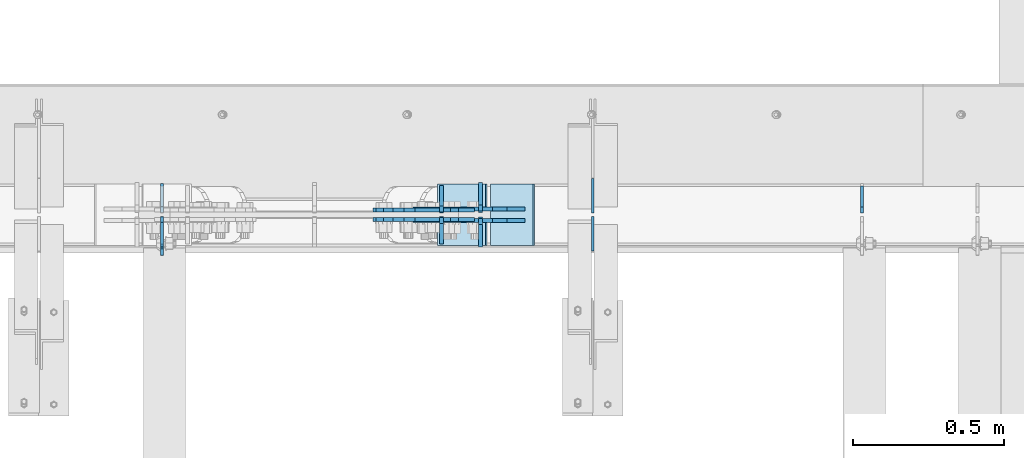
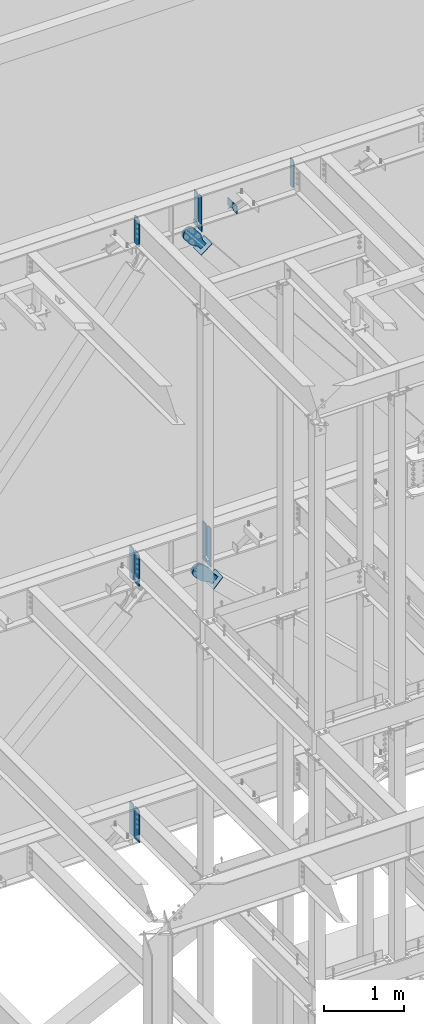
# One storey, part 1101 of 1179: 22 plates, 9 elements without a shape of their own.
"""IFC2X3 building model written with IfcOpenShell, lengths in millimetres."""

from ifc_helpers import new_model, si_unit, frame, origin_with_axes, place, context, subcontext, project, spatial, faceted_brep, material, type_object, element, aggregate, save


model = new_model("IFC2X3")

# Units and contexts
model_context = context("Model", 3, precision=1e-05, world=origin_with_axes())
body_context = subcontext(model_context, "Body", "Model", "MODEL_VIEW")
ifc_project = project(units=[si_unit("LENGTHUNIT", "METRE", prefix="MILLI"), si_unit("AREAUNIT", "SQUARE_METRE"), si_unit("VOLUMEUNIT", "CUBIC_METRE"), si_unit("MASSUNIT", "GRAM", prefix="KILO"), si_unit("TIMEUNIT", "SECOND"), si_unit("PLANEANGLEUNIT", "RADIAN"), si_unit("SOLIDANGLEUNIT", "STERADIAN"), si_unit("THERMODYNAMICTEMPERATUREUNIT", "DEGREE_CELSIUS"), si_unit("LUMINOUSINTENSITYUNIT", "LUMEN")], contexts=[model_context])

# Site, building, storey
site_placement = place(None, origin_with_axes())
site = spatial("IfcSite", under=ifc_project, at=site_placement, CompositionType="ELEMENT")
building_placement = place(site_placement, origin_with_axes())
building = spatial("IfcBuilding", under=site, at=building_placement, Name="Undefined", CompositionType="ELEMENT")
storey_placement = place(building_placement, origin_with_axes())
storey = spatial("IfcBuildingStorey", under=building, at=storey_placement, Name="Undefined", CompositionType="ELEMENT", Elevation=0.0)

# Assembly, plate
assembly_1_placement = place(storey_placement, origin_with_axes())
assembly_1 = element("IfcElementAssembly", 1, at=assembly_1_placement, inside=storey, Name="BEAM", AssemblyPlace="NOTDEFINED", PredefinedType="RIGID_FRAME")
ifc_material_1 = material(Name="STEEL/A36")
plate_type_1 = type_object("IfcPlateType", PredefinedType="NOTDEFINED")
plate_1_placement = place(assembly_1_placement, frame((11866.5620000839, 41193.24375, 12673.0125), z_axis=(0.0, 0.0, 1.0), x_axis=(0.0, -1.0, 0.0)))
plate_1 = element("IfcPlate", 2, at=plate_1_placement, type_object=plate_type_1, material=ifc_material_1, Name="PLATE", context=body_context, shape_type="Brep", body=[
    faceted_brep([(91.28125, -4.76250000000073, 425.450000000001), (91.28125, -4.76250000000073, 420.687499809264), (91.28125, 4.76250000000073, 420.687499809264), (91.28125, 4.76250000000073, 425.450000000001), (92.2479799225912, -4.76250000000073, 415.827420291219), (92.2479799225912, 4.76250000000073, 415.827420291219), (95.0009938230651, -4.76250000000073, 411.707243823065), (95.0009938230651, 4.76250000000073, 411.707243823065), (99.1211702912187, -4.76250000000073, 408.954229922587), (99.1211702912187, 4.76250000000073, 408.954229922587), (103.981249809265, -4.76250000000073, 407.987499999999), (103.981249809265, 4.76250000000073, 407.987499999999), (126.999999992826, -4.76249999999709, 407.9875), (127.0, 4.76249999999709, 407.9875), (0.0, -4.76249999999709, 406.400000762939), (19.0499992370605, -4.76249999999709, 425.45), (19.0499992370605, 4.76249999999709, 425.45), (0.0, 4.76249999999709, 406.400000762939), (0.0, -4.76250000000073, 19.0499992370605), (0.0, 4.76250000000073, 19.0499992370605), (19.0499992370605, -4.76250000000073, 0.0), (19.0499992370605, 4.76250000000073, 0.0), (127.0, -4.76250000000073, 0.0), (127.0, 4.76250000000073, 0.0)], [[[0, 1, 2, 3]], [[4, 5, 2, 1]], [[6, 7, 5, 4]], [[8, 9, 7, 6]], [[10, 11, 9, 8]], [[12, 13, 11, 10]], [[14, 15, 16, 17]], [[18, 14, 17, 19]], [[20, 18, 19, 21]], [[22, 20, 21, 23]], [[8, 6, 4, 1, 0, 15, 14, 18, 20, 22, 12, 10]], [[16, 15, 0, 3]], [[23, 21, 19, 17, 16, 3, 2, 5, 7, 9, 11, 13]], [[22, 23, 13, 12]]]),
])

assembly_2_placement = place(storey_placement, origin_with_axes())
assembly_2 = element("IfcElementAssembly", 3, at=assembly_2_placement, inside=storey, Name="BEAM", AssemblyPlace="NOTDEFINED", PredefinedType="RIGID_FRAME")
plate_2_placement = place(assembly_2_placement, frame((11866.5620000839, 41191.65625, 7489.825), z_axis=(0.0, 0.0, 1.0), x_axis=(0.0, -1.0, 0.0)))
plate_2 = element("IfcPlate", 4, at=plate_2_placement, type_object=plate_type_1, material=ifc_material_1, Name="PLATE", context=body_context, shape_type="Brep", body=[
    faceted_brep([(99.2187497618652, -4.76249999998072, 498.475), (99.21875, -4.76250000000073, 492.124999809264), (99.21875, 4.76250000000073, 492.124999809264), (99.2187499999927, 4.76250000001892, 498.475), (100.185479922588, -4.76250000000073, 487.264920291219), (100.185479922588, 4.76250000000073, 487.264920291219), (102.938493823065, -4.76250000000073, 483.144743823065), (102.938493823065, 4.76250000000073, 483.144743823065), (107.058670291219, -4.76250000000073, 480.391729922587), (107.058670291219, 4.76250000000073, 480.391729922587), (111.918749809265, -4.76250000000073, 479.424999999999), (111.918749809265, 4.76250000000073, 479.424999999999), (127.000007629395, -4.76250000000073, 479.424999999999), (127.000004683803, 4.76250000000073, 479.424999999999), (0.0, -4.76250000000073, 479.425006866455), (19.0499992370605, -4.76250000000073, 498.475006103516), (19.0499992370605, 4.76250000000073, 498.475006103516), (0.0, 4.76250000000073, 479.425006866455), (0.0, -4.76250000000073, 19.0499992370605), (0.0, 4.76250000000073, 19.0499992370605), (19.0499992370605, -4.76250000000073, 0.0), (19.0499992370605, 4.76250000000073, 0.0), (127.0, -4.76250000000073, 0.0), (127.0, 4.76250000000073, 0.0)], [[[0, 1, 2, 3]], [[4, 5, 2, 1]], [[6, 7, 5, 4]], [[8, 9, 7, 6]], [[10, 11, 9, 8]], [[12, 13, 11, 10]], [[14, 15, 16, 17]], [[18, 14, 17, 19]], [[20, 18, 19, 21]], [[22, 20, 21, 23]], [[8, 6, 4, 1, 0, 15, 14, 18, 20, 22, 12, 10]], [[16, 15, 0, 3]], [[23, 21, 19, 17, 16, 3, 2, 5, 7, 9, 11, 13]], [[22, 23, 13, 12]]]),
])

assembly_3_placement = place(storey_placement, origin_with_axes())
assembly_3 = element("IfcElementAssembly", 5, at=assembly_3_placement, inside=storey, Name="BEAM", AssemblyPlace="NOTDEFINED", PredefinedType="RIGID_FRAME")
plate_3_placement = place(assembly_3_placement, frame((11866.5619473748, 41191.6562498809, 3578.225), z_axis=(0.0, 0.0, 1.0), x_axis=(0.0, -1.0, 0.0)))
plate_3 = element("IfcPlate", 6, at=plate_3_placement, type_object=plate_type_1, material=ifc_material_1, Name="PLATE", context=body_context, shape_type="Brep", body=[
    faceted_brep([(100.185729626639, -4.76249977056068, 493.614920291231), (100.185729712364, 4.76250000001892, 493.614920291231), (99.2189997897731, 4.76250000002074, 498.475), (99.218999704055, -4.76249999998072, 498.475), (102.93874352712, -4.76249979533713, 489.494743823075), (102.938743612845, 4.76250000002074, 489.494743823075), (107.058919995281, -4.76249983241905, 486.741729922598), (107.058920081006, 4.76250000002074, 486.741729922598), (111.918999513335, -4.76249987616211, 485.775000000015), (111.918999599053, 4.76250000002074, 485.775000000015), (127.000004753965, -4.76249999997526, 485.775), (127.000004873044, 4.76250000002437, 485.775), (0.0, -4.76250000000073, 479.425006866455), (19.0499992370605, -4.76250000000073, 498.475006103516), (19.0499992370605, 4.76250000000073, 498.475006103516), (0.0, 4.76250000000073, 479.425006866455), (0.0, -4.76250000000073, 19.0499992370605), (0.0, 4.76250000000073, 19.0499992370605), (19.0499992370605, -4.76250000000073, 0.0), (19.0499992370605, 4.76250000000073, 0.0), (127.0, -4.76250000000073, 0.0), (127.0, 4.76250000000073, 0.0)], [[[0, 1, 2, 3]], [[4, 5, 1, 0]], [[6, 7, 5, 4]], [[8, 9, 7, 6]], [[10, 11, 9, 8]], [[12, 13, 14, 15]], [[16, 12, 15, 17]], [[18, 16, 17, 19]], [[20, 18, 19, 21]], [[6, 4, 0, 3, 13, 12, 16, 18, 20, 10, 8]], [[14, 13, 3, 2]], [[21, 19, 17, 15, 14, 2, 1, 5, 7, 9, 11]], [[20, 21, 11, 10]]]),
])

# Plate
plate_type_2 = type_object("IfcPlateType", PredefinedType="NOTDEFINED")
plate_4_placement = place(assembly_1_placement, frame((14177.9620000839, 41204.35625, 12673.0125), z_axis=(0.0, 0.0, 1.0), x_axis=(0.0, 1.0, 0.0)))
plate_4 = element("IfcPlate", 7, at=plate_4_placement, type_object=plate_type_2, material=ifc_material_1, Name="PLATE", context=body_context, shape_type="Brep", body=[
    faceted_brep([(0.0, -4.76250000000073, 19.0499992370605), (0.0, -4.76249999999709, 406.400000762939), (0.0, 4.76249999999709, 406.400000762939), (0.0, 4.76250000000073, 19.0499992370605), (19.0499992370605, -4.76249999999709, 425.45), (19.0499992370605, 4.76249999999709, 425.45), (88.9000015258789, -4.76250000000073, 425.450012207031), (88.9000015258789, 4.76250000000073, 425.450012207031), (88.8999999999996, -4.76250000000005, 0.0), (88.8999999999996, 4.76250000000005, 0.0), (19.0499992370605, -4.76250000000073, 0.0), (19.0499992370605, 4.76250000000073, 0.0)], [[[0, 1, 2, 3]], [[1, 4, 5, 2]], [[4, 6, 7, 5]], [[6, 8, 9, 7]], [[8, 10, 11, 9]], [[10, 0, 3, 11]], [[5, 7, 9, 11, 3, 2]], [[10, 8, 6, 4, 1, 0]]]),
])

ifc_material_2 = material(Name="STEEL/A572-GR.50")
plate_type_3 = type_object("IfcPlateType", PredefinedType="NOTDEFINED")
plate_5_placement = place(assembly_2_placement, frame((12918.0828125064, 41205.94375, 7489.825), z_axis=(0.0, 1.0, 0.0), x_axis=(0.0, 0.0, 1.0)))
plate_5 = element("IfcPlate", 8, at=plate_5_placement, type_object=plate_type_3, material=ifc_material_2, Name="PLATE", context=body_context, shape_type="Brep", body=[
    faceted_brep([(0.0, -6.34999999998763, 17.4624996185248), (0.0, -6.35000000000036, 99.21875), (0.0, 6.35000000000036, 99.21875), (0.0, 6.35000000000582, 17.4624996185175), (498.475, -6.35000000000036, 99.21875), (498.475, 6.35000000000036, 99.21875), (498.474999999775, -6.34999999979482, 17.4624996185303), (498.474999999769, 6.35000000019681, 17.4624996185303), (481.012500381255, -6.34999999980209, 0.0), (481.01250038125, 6.35000000019136, 0.0), (17.4624996185303, -6.34999999999309, 1.81898940354586e-12), (17.4624996185303, 6.34999999999854, -1.81898940354586e-12)], [[[0, 1, 2, 3]], [[1, 4, 5, 2]], [[4, 6, 7, 5]], [[6, 8, 9, 7]], [[8, 10, 11, 9]], [[10, 0, 3, 11]], [[5, 7, 9, 11, 3, 2]], [[10, 8, 6, 4, 1, 0]]]),
])

plate_6_placement = place(assembly_2_placement, frame((12918.0828125064, 41191.65625, 7489.825), z_axis=(0.0, -1.0, 0.0), x_axis=(0.0, 0.0, 1.0)))
plate_6 = element("IfcPlate", 9, at=plate_6_placement, type_object=plate_type_3, material=ifc_material_2, Name="PLATE", context=body_context, shape_type="Brep", body=[
    faceted_brep([(0.0, -6.34999999998763, 17.4624996185248), (0.0, -6.35000000000036, 99.21875), (0.0, 6.35000000000036, 99.21875), (0.0, 6.35000000000582, 17.4624996185175), (498.475, -6.35000000000036, 99.21875), (498.475, 6.35000000000036, 99.21875), (498.474999999775, -6.34999999979482, 17.4624996185303), (498.474999999769, 6.35000000019681, 17.4624996185303), (481.012500381255, -6.34999999980209, 0.0), (481.01250038125, 6.35000000019136, 0.0), (17.4624996185303, -6.34999999999309, 1.81898940354586e-12), (17.4624996185303, 6.34999999999854, -1.81898940354586e-12)], [[[0, 1, 2, 3]], [[1, 4, 5, 2]], [[4, 6, 7, 5]], [[6, 8, 9, 7]], [[8, 10, 11, 9]], [[10, 0, 3, 11]], [[5, 7, 9, 11, 3, 2]], [[10, 8, 6, 4, 1, 0]]]),
])

plate_type_4 = type_object("IfcPlateType", PredefinedType="NOTDEFINED")
plate_7_placement = place(assembly_2_placement, frame((11866.5620000839, 41205.94375, 7489.825), z_axis=(0.0, 0.0, 1.0), x_axis=(0.0, 1.0, 0.0)))
plate_7 = element("IfcPlate", 10, at=plate_7_placement, type_object=plate_type_4, material=ifc_material_1, Name="PLATE", context=body_context, shape_type="Brep", body=[
    faceted_brep([(0.0, -4.76250000000073, 19.0499992370605), (0.0, -4.76250000000073, 479.425006866455), (0.0, 4.76250000000073, 479.425006866455), (0.0, 4.76250000000073, 19.0499992370605), (19.0499992370605, -4.76250000000073, 498.475006103516), (19.0499992370605, 4.76250000000073, 498.475006103516), (95.25, -4.76250000000073, 498.475006103516), (95.25, 4.76250000000073, 498.475006103516), (95.25, -4.76250000000073, 0.0), (95.25, 4.76250000000073, 0.0), (19.0499992370605, -4.76250000000073, 0.0), (19.0499992370605, 4.76250000000073, 0.0)], [[[0, 1, 2, 3]], [[1, 4, 5, 2]], [[4, 6, 7, 5]], [[6, 8, 9, 7]], [[8, 10, 11, 9]], [[10, 0, 3, 11]], [[5, 7, 9, 11, 3, 2]], [[10, 8, 6, 4, 1, 0]]]),
])

plate_8_placement = place(assembly_3_placement, frame((11866.5619473541, 41205.94375, 3578.225), z_axis=(0.0, 0.0, 1.0), x_axis=(0.0, 1.0, 0.0)))
plate_8 = element("IfcPlate", 11, at=plate_8_placement, type_object=plate_type_4, material=ifc_material_1, Name="PLATE", context=body_context, shape_type="Brep", body=[
    faceted_brep([(0.0, -4.76250000000073, 19.0499992370605), (0.0, -4.76250000000073, 479.425006866455), (0.0, 4.76250000000073, 479.425006866455), (0.0, 4.76250000000073, 19.0499992370605), (19.0499992370605, -4.76250000000073, 498.475006103516), (19.0499992370605, 4.76250000000073, 498.475006103516), (95.25, -4.76250000000073, 498.475006103516), (95.25, 4.76250000000073, 498.475006103516), (95.25, -4.76250000000073, 0.0), (95.25, 4.76250000000073, 0.0), (19.0499992370605, -4.76250000000073, 0.0), (19.0499992370605, 4.76250000000073, 0.0)], [[[0, 1, 2, 3]], [[1, 4, 5, 2]], [[4, 6, 7, 5]], [[6, 8, 9, 7]], [[8, 10, 11, 9]], [[10, 0, 3, 11]], [[5, 7, 9, 11, 3, 2]], [[10, 8, 6, 4, 1, 0]]]),
])

aggregate(assembly_3, [plate_8, plate_3])

# Assembly, plate
assembly_4_placement = place(storey_placement, origin_with_axes())
assembly_4 = element("IfcElementAssembly", 12, at=assembly_4_placement, inside=storey, Name="Plate", AssemblyPlace="NOTDEFINED", PredefinedType="RIGID_FRAME")
plate_type_5 = type_object("IfcPlateType", PredefinedType="NOTDEFINED")
plate_9_placement = place(assembly_4_placement, frame((12778.2065319838, 41300.4, 12208.4235723899), z_axis=(0.782937860640373, 0.0, 0.622099916714249), x_axis=(0.0, -1.0, 0.0)))
plate_9 = element("IfcPlate", 13, at=plate_9_placement, type_object=plate_type_5, material=ifc_material_1, Name="Plate", context=body_context, shape_type="Brep", body=[
    faceted_brep([(0.0, -3.17500000000109, 0.0), (0.0, -3.17500000000291, 203.200000000368), (0.0, 3.17499999998836, 203.200000000361), (0.0, 3.17500000000109, 7.27595761418343e-12), (203.199999999997, -3.17500000000291, 203.200000000368), (203.199999999997, 3.17499999998836, 203.200000000361), (203.199999999997, -3.17499999999927, 3.63797880709171e-12), (203.199999999997, 3.17499999999382, -3.63797880709171e-12)], [[[0, 1, 2, 3]], [[1, 4, 5, 2]], [[4, 6, 7, 5]], [[6, 0, 3, 7]], [[5, 7, 3, 2]], [[6, 4, 1, 0]]]),
])
aggregate(assembly_4, [plate_9])

assembly_5_placement = place(storey_placement, origin_with_axes())
assembly_5 = element("IfcElementAssembly", 14, at=assembly_5_placement, inside=storey, Name="Plate", AssemblyPlace="NOTDEFINED", PredefinedType="RIGID_FRAME")
plate_10_placement = place(assembly_5_placement, frame((12953.4754471268, 41300.4, 7040.16901450949), z_axis=(0.691222646058185, 0.0, 0.722641857060828), x_axis=(0.0, -1.0, 0.0)))
plate_10 = element("IfcPlate", 15, at=plate_10_placement, type_object=plate_type_5, material=ifc_material_1, Name="Plate", context=body_context, shape_type="Brep", body=[
    faceted_brep([(0.0, -3.17500000000109, 0.0), (0.0, -3.17500000000291, 203.200000000368), (0.0, 3.17499999998836, 203.200000000361), (0.0, 3.17500000000109, 7.27595761418343e-12), (203.199999999997, -3.17500000000291, 203.200000000368), (203.199999999997, 3.17499999998836, 203.200000000361), (203.199999999997, -3.17499999999927, 3.63797880709171e-12), (203.199999999997, 3.17499999999382, -3.63797880709171e-12)], [[[0, 1, 2, 3]], [[1, 4, 5, 2]], [[4, 6, 7, 5]], [[6, 0, 3, 7]], [[5, 7, 3, 2]], [[6, 4, 1, 0]]]),
])
aggregate(assembly_5, [plate_10])

# Plate
plate_type_6 = type_object("IfcPlateType", PredefinedType="NOTDEFINED")
plate_11_placement = place(assembly_1_placement, frame((12788.9, 41208.325, 12652.375), z_axis=(0.0, 1.0, 0.0), x_axis=(0.0, 0.0, -1.0)))
plate_11 = element("IfcPlate", 16, at=plate_11_placement, type_object=plate_type_6, material=ifc_material_2, Name="PLATE", context=body_context, shape_type="Brep", body=[
    faceted_brep([(0.0, 6.35000000000036, 19.0499999999993), (19.0500000000002, 6.35000000000036, 0.0), (19.0500000000002, -6.35000000000036, 0.0), (0.0, -6.35000000000036, 19.0499999999993), (0.0, -6.35000000000036, 87.3125), (0.0, 6.35000000000036, 87.3125), (88.7851254133348, -6.35000000000036, 87.3125), (88.7851254133348, 6.35000000000036, 87.3125), (88.7851254133348, -6.35000000000036, 0.0), (88.7851254133348, 6.35000000000036, 0.0)], [[[0, 1, 2, 3]], [[4, 5, 0, 3]], [[4, 6, 7, 5]], [[6, 8, 9, 7]], [[9, 8, 2, 1]], [[5, 7, 9, 1, 0]], [[8, 6, 4, 3, 2]]]),
])

plate_12_placement = place(assembly_1_placement, frame((12788.9, 41189.275, 12652.375), z_axis=(0.0, -1.0, 0.0), x_axis=(0.0, 0.0, -1.0)))
plate_12 = element("IfcPlate", 17, at=plate_12_placement, type_object=plate_type_6, material=ifc_material_2, Name="PLATE", context=body_context, shape_type="Brep", body=[
    faceted_brep([(0.0, 6.35000000000036, 19.0499999999993), (19.0500000000002, 6.35000000000036, 0.0), (19.0500000000002, -6.35000000000036, 0.0), (0.0, -6.35000000000036, 19.0499999999993), (0.0, -6.35000000000036, 87.3125), (0.0, 6.35000000000036, 87.3125), (88.7851254133348, -6.35000000000036, 87.3125), (88.7851254133348, 6.35000000000036, 87.3125), (88.7851254133348, -6.35000000000036, 0.0), (88.7851254133348, 6.35000000000036, 0.0)], [[[0, 1, 2, 3]], [[4, 5, 0, 3]], [[4, 6, 7, 5]], [[6, 8, 9, 7]], [[9, 8, 2, 1]], [[5, 7, 9, 1, 0]], [[8, 6, 4, 3, 2]]]),
])

plate_type_7 = type_object("IfcPlateType", PredefinedType="NOTDEFINED")
plate_13_placement = place(assembly_1_placement, frame((12788.9, 41104.34375, 12673.0125), z_axis=(0.0, 0.0, 1.0), x_axis=(0.0, 1.0, 0.0)))
plate_13 = element("IfcPlate", 18, at=plate_13_placement, type_object=plate_type_7, material=ifc_material_2, Name="PLATE", context=body_context, shape_type="Brep", body=[
    faceted_brep([(0.0, -6.34999999999854, 0.0), (0.0, -6.34999999999991, 425.450012207031), (0.0, 6.34999999999991, 425.450012207031), (0.0, 6.34999999999854, 0.0), (69.8500022888184, -6.34999999999991, 425.450012207031), (69.8500022888184, 6.34999999999991, 425.450012207031), (88.9000015258789, -6.34999999999991, 406.400012969971), (88.9000015258789, 6.34999999999991, 406.400012969971), (88.9000015258789, -6.34999999999991, 19.0499992370605), (88.9000015258789, 6.34999999999991, 19.0499992370605), (69.849999425729, -6.34999999999854, 0.0), (69.849999425729, 6.34999999999854, 0.0)], [[[0, 1, 2, 3]], [[1, 4, 5, 2]], [[4, 6, 7, 5]], [[6, 8, 9, 7]], [[8, 10, 11, 9]], [[10, 0, 3, 11]], [[5, 7, 9, 11, 3, 2]], [[10, 8, 6, 4, 1, 0]]]),
])

plate_14_placement = place(assembly_1_placement, frame((12788.9, 41204.35625, 12673.0125), z_axis=(0.0, 0.0, 1.0), x_axis=(0.0, 1.0, 0.0)))
plate_14 = element("IfcPlate", 19, at=plate_14_placement, type_object=plate_type_7, material=ifc_material_2, Name="PLATE", context=body_context, shape_type="Brep", body=[
    faceted_brep([(0.0, -6.35000000000036, 19.0499999999993), (0.0, -6.34999999999991, 406.400012969971), (0.0, 6.34999999999991, 406.400012969971), (0.0, 6.35000000000036, 19.0499999999993), (19.0499992370605, -6.34999999999991, 425.450012207031), (19.0499992370605, 6.34999999999991, 425.450012207031), (88.9000015258789, -6.34999999999991, 425.450012207031), (88.9000015258789, 6.34999999999991, 425.450012207031), (88.9000015258789, -6.34999999999991, 0.0), (88.9000015258789, 6.34999999999991, 0.0), (19.0500000000002, -6.35000000000036, 0.0), (19.0500000000002, 6.35000000000036, 0.0)], [[[0, 1, 2, 3]], [[1, 4, 5, 2]], [[4, 6, 7, 5]], [[6, 8, 9, 7]], [[8, 10, 11, 9]], [[3, 11, 10, 0]], [[5, 7, 9, 11, 3, 2]], [[10, 8, 6, 4, 1, 0]]]),
])

plate_type_8 = type_object("IfcPlateType", PredefinedType="NOTDEFINED")
plate_15_placement = place(assembly_2_placement, frame((12918.0828125064, 41211.5, 7464.42500040788), z_axis=(0.0, 1.0, 0.0), x_axis=(0.0, 0.0, -1.0)))
plate_15 = element("IfcPlate", 20, at=plate_15_placement, type_object=plate_type_8, material=ifc_material_2, Name="PLATE", context=body_context, shape_type="Brep", body=[
    faceted_brep([(0.0, 6.35000000000036, 19.0499999999993), (19.0500000000002, 6.35000000000036, 0.0), (19.0500000000002, -6.35000000000036, 0.0), (0.0, -6.35000000000036, 19.0499999999993), (0.0, -6.35000000000036, 93.6625000000058), (0.0, 6.35000000000036, 93.6625000000058), (63.5020087381745, -6.35000000000036, 93.6625000000058), (63.5020087381745, 6.35000000000036, 93.6625000000058), (63.5020087381745, -6.35000000000036, 0.0), (63.5020087381745, 6.35000000000036, 0.0)], [[[0, 1, 2, 3]], [[4, 5, 0, 3]], [[4, 6, 7, 5]], [[6, 8, 9, 7]], [[9, 8, 2, 1]], [[5, 7, 9, 1, 0]], [[8, 6, 4, 3, 2]]]),
])

plate_16_placement = place(assembly_2_placement, frame((12918.0828125064, 41186.1, 7464.42500040788), z_axis=(0.0, -1.0, 0.0), x_axis=(0.0, 0.0, -1.0)))
plate_16 = element("IfcPlate", 21, at=plate_16_placement, type_object=plate_type_8, material=ifc_material_2, Name="PLATE", context=body_context, shape_type="Brep", body=[
    faceted_brep([(0.0, 6.35000000000036, 19.0499999999993), (19.0500000000002, 6.35000000000036, 0.0), (19.0500000000002, -6.35000000000036, 0.0), (0.0, -6.35000000000036, 19.0499999999993), (0.0, -6.35000000000036, 93.6625000000058), (0.0, 6.35000000000036, 93.6625000000058), (63.5020087381745, -6.35000000000036, 93.6625000000058), (63.5020087381745, 6.35000000000036, 93.6625000000058), (63.5020087381745, -6.35000000000036, 0.0), (63.5020087381745, 6.35000000000036, 0.0)], [[[0, 1, 2, 3]], [[4, 5, 0, 3]], [[4, 6, 7, 5]], [[6, 8, 9, 7]], [[9, 8, 2, 1]], [[5, 7, 9, 1, 0]], [[8, 6, 4, 3, 2]]]),
])

aggregate(assembly_2, [plate_15, plate_16, plate_5, plate_6, plate_7, plate_2])

# Assembly, plate
assembly_6_placement = place(storey_placement, origin_with_axes())
assembly_6 = element("IfcElementAssembly", 22, at=assembly_6_placement, inside=storey, AssemblyPlace="NOTDEFINED", PredefinedType="RIGID_FRAME")
plate_type_9 = type_object("IfcPlateType", PredefinedType="NOTDEFINED")
plate_17_placement = place(assembly_6_placement, frame((12846.4064600926, 41214.675, 12363.9942449933), z_axis=(-0.782937860640373, 0.0, -0.622099916714249), x_axis=(0.622099916714252, 0.0, -0.782937860640371)))
plate_17 = element("IfcPlate", 23, at=plate_17_placement, type_object=plate_type_9, material=ifc_material_1, context=body_context, shape_type="Brep", body=[
    faceted_brep([(0.0, -6.34999999999854, 0.0), (-101.600000000007, -6.34999999999854, -45.085691726028), (-101.600000000007, 6.34999999999854, -45.085691726028), (0.0, 6.34999999999854, 0.0), (-245.369242322517, -6.34999999999854, -45.085691725908), (-245.369242322517, 6.34999999999854, -45.085691725908), (-281.212328722571, -6.34999999999854, -37.9560585558283), (-281.212328722571, 6.34999999999854, -37.9560585558283), (-311.598630136563, -6.34999999999854, -17.6525810655148), (-311.598630136563, 6.34999999999854, -17.6525810655148), (-331.902107626699, -6.34999999999854, 12.7337203485949), (-331.902107626699, 6.34999999999854, 12.7337203485949), (-339.031740796561, -6.34999999999854, 48.5768098006738), (-339.031740796561, 6.34999999999854, 48.5768098006738), (-331.902107626408, -6.34999999999854, 84.4198962005139), (-331.902107626408, 6.34999999999854, 84.4198962005139), (-311.598630136172, -6.34999999999854, 114.806197614322), (-311.598630136172, 6.34999999999854, 114.806197614322), (-281.212328722244, -6.34999999999854, 135.109675104381), (-281.212328722244, 6.34999999999854, 135.109675104381), (-245.369240796288, -6.34999999999854, 142.239308274318), (-245.369240796288, 6.34999999999854, 142.239308274318), (-101.599999999052, -6.34999999999854, 142.239308274202), (-101.599999999052, 6.34999999999854, 142.239308274202), (4.938556230627e-10, -6.34999999999854, 97.1536165479993), (4.938556230627e-10, 6.34999999999854, 97.1536165479993), (82.5500000003167, -6.34999999999854, 97.1536165479301), (82.5500000003167, 6.34999999999854, 97.1536165479301), (82.550000000203, -6.34999999999854, 1.2732925824821e-10), (82.550000000203, 6.34999999999854, 1.2732925824821e-10)], [[[0, 1, 2, 3]], [[1, 4, 5, 2]], [[4, 6, 7, 5]], [[6, 8, 9, 7]], [[8, 10, 11, 9]], [[10, 12, 13, 11]], [[12, 14, 15, 13]], [[14, 16, 17, 15]], [[16, 18, 19, 17]], [[18, 20, 21, 19]], [[20, 22, 23, 21]], [[22, 24, 25, 23]], [[24, 26, 27, 25]], [[26, 28, 29, 27]], [[28, 0, 3, 29]], [[5, 7, 9, 11, 13, 15, 17, 19, 21, 23, 25, 27, 29, 3, 2]], [[28, 26, 24, 22, 20, 18, 16, 14, 12, 10, 8, 6, 4, 1, 0]]]),
])
aggregate(assembly_6, [plate_17])

assembly_7_placement = place(storey_placement, origin_with_axes())
assembly_7 = element("IfcElementAssembly", 24, at=assembly_7_placement, inside=storey, AssemblyPlace="NOTDEFINED", PredefinedType="RIGID_FRAME")
plate_18_placement = place(assembly_7_placement, frame((12846.4064600926, 41182.925, 12363.9942449933), z_axis=(-0.782937860640373, 0.0, -0.622099916714249), x_axis=(0.622099916714252, 0.0, -0.782937860640371)))
plate_18 = element("IfcPlate", 25, at=plate_18_placement, type_object=plate_type_9, material=ifc_material_1, context=body_context, shape_type="Brep", body=[
    faceted_brep([(0.0, -6.34999999999854, 0.0), (-101.600000000007, -6.34999999999854, -45.085691726028), (-101.600000000007, 6.34999999999854, -45.085691726028), (0.0, 6.34999999999854, 0.0), (-245.369242322517, -6.34999999999854, -45.085691725908), (-245.369242322517, 6.34999999999854, -45.085691725908), (-281.212328722571, -6.34999999999854, -37.9560585558283), (-281.212328722571, 6.34999999999854, -37.9560585558283), (-311.598630136563, -6.34999999999854, -17.6525810655148), (-311.598630136563, 6.34999999999854, -17.6525810655148), (-331.902107626699, -6.34999999999854, 12.7337203485949), (-331.902107626699, 6.34999999999854, 12.7337203485949), (-339.031740796561, -6.34999999999854, 48.5768098006738), (-339.031740796561, 6.34999999999854, 48.5768098006738), (-331.902107626408, -6.34999999999854, 84.4198962005139), (-331.902107626408, 6.34999999999854, 84.4198962005139), (-311.598630136172, -6.34999999999854, 114.806197614322), (-311.598630136172, 6.34999999999854, 114.806197614322), (-281.212328722244, -6.34999999999854, 135.109675104381), (-281.212328722244, 6.34999999999854, 135.109675104381), (-245.369240796288, -6.34999999999854, 142.239308274318), (-245.369240796288, 6.34999999999854, 142.239308274318), (-101.599999999052, -6.34999999999854, 142.239308274202), (-101.599999999052, 6.34999999999854, 142.239308274202), (4.938556230627e-10, -6.34999999999854, 97.1536165479993), (4.938556230627e-10, 6.34999999999854, 97.1536165479993), (82.5500000003167, -6.34999999999854, 97.1536165479301), (82.5500000003167, 6.34999999999854, 97.1536165479301), (82.550000000203, -6.34999999999854, 1.2732925824821e-10), (82.550000000203, 6.34999999999854, 1.2732925824821e-10)], [[[0, 1, 2, 3]], [[1, 4, 5, 2]], [[4, 6, 7, 5]], [[6, 8, 9, 7]], [[8, 10, 11, 9]], [[10, 12, 13, 11]], [[12, 14, 15, 13]], [[14, 16, 17, 15]], [[16, 18, 19, 17]], [[18, 20, 21, 19]], [[20, 22, 23, 21]], [[22, 24, 25, 23]], [[24, 26, 27, 25]], [[26, 28, 29, 27]], [[28, 0, 3, 29]], [[5, 7, 9, 11, 13, 15, 17, 19, 21, 23, 25, 27, 29, 3, 2]], [[28, 26, 24, 22, 20, 18, 16, 14, 12, 10, 8, 6, 4, 1, 0]]]),
])
aggregate(assembly_7, [plate_18])

assembly_8_placement = place(storey_placement, origin_with_axes())
assembly_8 = element("IfcElementAssembly", 26, at=assembly_8_placement, inside=storey, AssemblyPlace="NOTDEFINED", PredefinedType="RIGID_FRAME")
plate_19_placement = place(assembly_8_placement, frame((13005.1163529212, 41217.85, 7208.98998808252), z_axis=(-0.691222646058184, 0.0, -0.722641857060828), x_axis=(0.722641857060828, 0.0, -0.691222646058184)))
plate_19 = element("IfcPlate", 27, at=plate_19_placement, type_object=plate_type_9, material=ifc_material_1, context=body_context, shape_type="Brep", body=[
    faceted_brep([(0.0, -6.34999999999854, 0.0), (-101.599999999963, -6.34999999999854, -37.5700345970108), (-101.599999999963, 6.34999999999854, -37.5700345970108), (0.0, 6.34999999999854, 0.0), (-245.369242323884, -6.34999999999854, -37.5700345970945), (-245.369242323884, 6.34999999999854, -37.5700345970945), (-281.212328723803, -6.34999999999854, -30.4404014271258), (-281.212328723803, 6.34999999999854, -30.4404014271258), (-311.598630137756, -6.34999999999854, -10.1369239370142), (-311.598630137756, 6.34999999999854, -10.1369239370142), (-331.902107627997, -6.34999999999854, 20.24937747687), (-331.902107627997, 6.34999999999854, 20.24937747687), (-339.031740798124, -6.34999999999854, 56.0924669287269), (-339.031740798124, 6.34999999999854, 56.0924669287269), (-331.902107628228, -6.34999999999854, 91.9355533287926), (-331.902107628228, 6.34999999999854, 91.9355533287926), (-311.598630138099, -6.34999999999854, 122.321854742866), (-311.598630138099, 6.34999999999854, 122.321854742866), (-281.212328724136, -6.34999999999854, 142.625332233139), (-281.212328724136, 6.34999999999854, 142.625332233139), (-245.36924079839, -6.34999999999854, 149.754965403199), (-245.36924079839, 6.34999999999854, 149.754965403199), (-101.600000000685, -6.34999999999854, 149.75496540329), (-101.600000000685, 6.34999999999854, 149.75496540329), (-4.35647962149233e-10, -6.34999999999854, 112.184930806416), (-4.35647962149233e-10, 6.34999999999854, 112.184930806416), (82.5499999996491, -6.34999999999854, 112.184930806461), (82.5499999996491, 6.34999999999854, 112.184930806461), (82.550000000203, -6.34999999999854, 1.2732925824821e-10), (82.550000000203, 6.34999999999854, 1.2732925824821e-10)], [[[0, 1, 2, 3]], [[1, 4, 5, 2]], [[4, 6, 7, 5]], [[6, 8, 9, 7]], [[8, 10, 11, 9]], [[10, 12, 13, 11]], [[12, 14, 15, 13]], [[14, 16, 17, 15]], [[16, 18, 19, 17]], [[18, 20, 21, 19]], [[20, 22, 23, 21]], [[22, 24, 25, 23]], [[24, 26, 27, 25]], [[26, 28, 29, 27]], [[28, 0, 3, 29]], [[5, 7, 9, 11, 13, 15, 17, 19, 21, 23, 25, 27, 29, 3, 2]], [[28, 26, 24, 22, 20, 18, 16, 14, 12, 10, 8, 6, 4, 1, 0]]]),
])
aggregate(assembly_8, [plate_19])

assembly_9_placement = place(storey_placement, origin_with_axes())
assembly_9 = element("IfcElementAssembly", 28, at=assembly_9_placement, inside=storey, AssemblyPlace="NOTDEFINED", PredefinedType="RIGID_FRAME")
plate_20_placement = place(assembly_9_placement, frame((13005.1163529212, 41179.75, 7208.98998808252), z_axis=(-0.691222646058184, 0.0, -0.722641857060828), x_axis=(0.722641857060828, 0.0, -0.691222646058184)))
plate_20 = element("IfcPlate", 29, at=plate_20_placement, type_object=plate_type_9, material=ifc_material_1, context=body_context, shape_type="Brep", body=[
    faceted_brep([(0.0, -6.34999999999854, 0.0), (-101.599999999963, -6.34999999999854, -37.5700345970108), (-101.599999999963, 6.34999999999854, -37.5700345970108), (0.0, 6.34999999999854, 0.0), (-245.369242323884, -6.34999999999854, -37.5700345970945), (-245.369242323884, 6.34999999999854, -37.5700345970945), (-281.212328723803, -6.34999999999854, -30.4404014271258), (-281.212328723803, 6.34999999999854, -30.4404014271258), (-311.598630137756, -6.34999999999854, -10.1369239370142), (-311.598630137756, 6.34999999999854, -10.1369239370142), (-331.902107627997, -6.34999999999854, 20.24937747687), (-331.902107627997, 6.34999999999854, 20.24937747687), (-339.031740798124, -6.34999999999854, 56.0924669287269), (-339.031740798124, 6.34999999999854, 56.0924669287269), (-331.902107628228, -6.34999999999854, 91.9355533287926), (-331.902107628228, 6.34999999999854, 91.9355533287926), (-311.598630138099, -6.34999999999854, 122.321854742866), (-311.598630138099, 6.34999999999854, 122.321854742866), (-281.212328724136, -6.34999999999854, 142.625332233139), (-281.212328724136, 6.34999999999854, 142.625332233139), (-245.36924079839, -6.34999999999854, 149.754965403199), (-245.36924079839, 6.34999999999854, 149.754965403199), (-101.600000000685, -6.34999999999854, 149.75496540329), (-101.600000000685, 6.34999999999854, 149.75496540329), (-4.35647962149233e-10, -6.34999999999854, 112.184930806416), (-4.35647962149233e-10, 6.34999999999854, 112.184930806416), (82.5499999996491, -6.34999999999854, 112.184930806461), (82.5499999996491, 6.34999999999854, 112.184930806461), (82.550000000203, -6.34999999999854, 1.2732925824821e-10), (82.550000000203, 6.34999999999854, 1.2732925824821e-10)], [[[0, 1, 2, 3]], [[1, 4, 5, 2]], [[4, 6, 7, 5]], [[6, 8, 9, 7]], [[8, 10, 11, 9]], [[10, 12, 13, 11]], [[12, 14, 15, 13]], [[14, 16, 17, 15]], [[16, 18, 19, 17]], [[18, 20, 21, 19]], [[20, 22, 23, 21]], [[22, 24, 25, 23]], [[24, 26, 27, 25]], [[26, 28, 29, 27]], [[28, 0, 3, 29]], [[5, 7, 9, 11, 13, 15, 17, 19, 21, 23, 25, 27, 29, 3, 2]], [[28, 26, 24, 22, 20, 18, 16, 14, 12, 10, 8, 6, 4, 1, 0]]]),
])
aggregate(assembly_9, [plate_20])

# Plate
plate_type_10 = type_object("IfcPlateType", PredefinedType="NOTDEFINED")
plate_21_placement = place(assembly_1_placement, frame((13288.9625, 41193.24375, 12690.4749987075), z_axis=(0.0, -0.707106781186506, 0.707106781186589), x_axis=(0.0, -0.70710678118659, -0.707106781186505)))
plate_21 = element("IfcPlate", 30, at=plate_21_placement, type_object=plate_type_10, material=ifc_material_1, Name="PLATE", context=body_context, shape_type="Brep", body=[
    faceted_brep([(0.0, -4.76249999999709, 0.0), (-67.3519210815575, -4.76250000000073, 67.3519210815502), (-67.3519210815575, 4.76250000000073, 67.3519210815502), (0.0, 4.76249999999709, 0.0), (13.4703845975746, -4.76250000000073, 148.174224853334), (13.4703845975746, 4.76250000000073, 148.174224853334), (94.2926864622132, -4.76250000000073, 67.3519210813465), (94.2926864622132, 4.76250000000073, 67.3519210813465), (26.9407683631525, -4.76249999999709, -6.18456397205591e-11), (26.9407683631525, 4.76249999999709, -6.18456397205591e-11)], [[[0, 1, 2, 3]], [[1, 4, 5, 2]], [[4, 6, 7, 5]], [[6, 8, 9, 7]], [[8, 0, 3, 9]], [[5, 7, 9, 3, 2]], [[8, 6, 4, 1, 0]]]),
])

plate_22_placement = place(assembly_1_placement, frame((13288.9625, 41204.35625, 12690.4749987075), z_axis=(0.0, 0.707106781186542, 0.707106781186553), x_axis=(0.0, 0.707106781186553, -0.707106781186542)))
plate_22 = element("IfcPlate", 31, at=plate_22_placement, type_object=plate_type_10, material=ifc_material_1, Name="PLATE", context=body_context, shape_type="Brep", body=[
    faceted_brep([(0.0, -4.76249999999709, 0.0), (-67.3519210815575, -4.76250000000073, 67.3519210815502), (-67.3519210815575, 4.76250000000073, 67.3519210815502), (0.0, 4.76249999999709, 0.0), (13.4703845975746, -4.76250000000073, 148.174224853334), (13.4703845975746, 4.76250000000073, 148.174224853334), (94.2926864622132, -4.76250000000073, 67.3519210813465), (94.2926864622132, 4.76250000000073, 67.3519210813465), (26.9407683631525, -4.76249999999709, -6.18456397205591e-11), (26.9407683631525, 4.76249999999709, -6.18456397205591e-11)], [[[0, 1, 2, 3]], [[1, 4, 5, 2]], [[4, 6, 7, 5]], [[6, 8, 9, 7]], [[8, 0, 3, 9]], [[5, 7, 9, 3, 2]], [[8, 6, 4, 1, 0]]]),
])

aggregate(assembly_1, [plate_13, plate_14, plate_11, plate_12, plate_21, plate_22, plate_4, plate_1])

save(model, "model.ifc")
